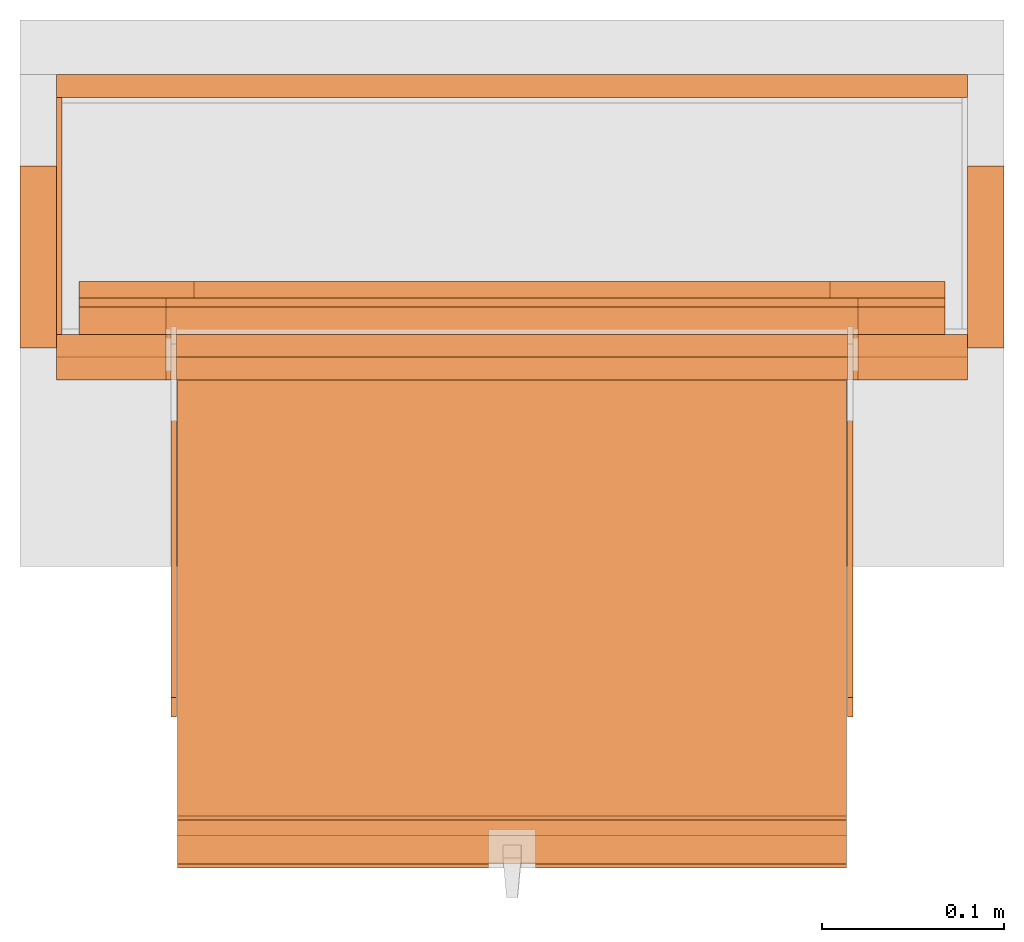
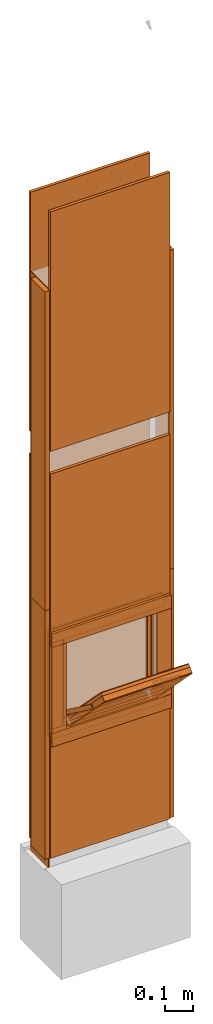
# One storey, part 1 of 3: 32 proxies, 1 opening.
"""IFC2X3 building model written with IfcOpenShell, lengths in metres."""

from ifc_helpers import new_model, entity, si_unit, converted_unit, derived_unit, money_unit, direction, frame, origin_with_axes, origin_2d_with_axis, place, context, subcontext, project, spatial, polyline, rectangle, outline, extrude, faceted_brep, source, transform, mapped, material, type_object, element, save


model = new_model("IFC2X3")

# Units and contexts
model_context = context("Model", 3, precision=1e-05, world=origin_with_axes(), true_north=direction((0.0, 1.0)))
plan_context = context("Plan", 3, precision=1e-05, world=origin_with_axes(), true_north=direction((0.0, 1.0)))
body_context = subcontext(model_context, "Body", "Model", "MODEL_VIEW")
ifc_project = project(units=[si_unit("LENGTHUNIT", "METRE"), si_unit("AREAUNIT", "SQUARE_METRE"), si_unit("VOLUMEUNIT", "CUBIC_METRE"), converted_unit("PLANEANGLEUNIT", "DEGREE", entity("IfcPlaneAngleMeasure", 0.0174532925199), si_unit("PLANEANGLEUNIT", "RADIAN"), dimensions=[0, 0, 0, 0, 0, 0, 0]), si_unit("SOLIDANGLEUNIT", "STERADIAN"), money_unit("CHF"), converted_unit("TIMEUNIT", "Year", entity("IfcTimeMeasure", 31556926.0), si_unit("TIMEUNIT", "SECOND"), dimensions=[0, 0, 1, 0, 0, 0, 0]), si_unit("MASSUNIT", "GRAM", prefix="KILO"), si_unit("THERMODYNAMICTEMPERATUREUNIT", "DEGREE_CELSIUS"), si_unit("LUMINOUSINTENSITYUNIT", "LUMEN"), si_unit("ENERGYUNIT", "JOULE", prefix="MEGA"), derived_unit("THERMALCONDUCTANCEUNIT", [(si_unit("POWERUNIT", "WATT"), 1), (si_unit("LENGTHUNIT", "METRE"), -1), (si_unit("THERMODYNAMICTEMPERATUREUNIT", "KELVIN"), -1)]), derived_unit("SPECIFICHEATCAPACITYUNIT", [(si_unit("ENERGYUNIT", "JOULE"), 1), (si_unit("MASSUNIT", "GRAM", prefix="KILO"), -1), (si_unit("THERMODYNAMICTEMPERATUREUNIT", "KELVIN"), -1)]), derived_unit("MASSDENSITYUNIT", [(si_unit("MASSUNIT", "GRAM", prefix="KILO"), 1), (si_unit("VOLUMEUNIT", "CUBIC_METRE"), -1)])], contexts=[model_context, plan_context])

# Site, building, storey
site_placement = place(None, origin_with_axes())
site = spatial("IfcSite", under=ifc_project, at=site_placement, CompositionType="ELEMENT")
building_placement = place(site_placement, origin_with_axes())
building = spatial("IfcBuilding", under=site, at=building_placement, CompositionType="ELEMENT")
storey_placement = place(building_placement, origin_with_axes())
storey = spatial("IfcBuildingStorey", under=building, at=storey_placement, Name="EG00", CompositionType="ELEMENT", Elevation=0.0)

# Proxies
ifc_material_1 = material(Name="Metall, Stahl")
building_element_proxy_type_1 = type_object("IfcBuildingElementProxyType", Name="Metall, Stahl 3", PredefinedType="NOTDEFINED")
proxy_1_placement = place(storey_placement, frame((1.55655524907, -3.75878861887, 1.15), z_axis=(0.0, 0.0, 1.0), x_axis=(0.0, -1.0, 0.0)))
element("IfcBuildingElementProxy", 1, at=proxy_1_placement, inside=storey, type_object=building_element_proxy_type_1, material=ifc_material_1, Name="Wand-005", context=body_context, shape_type="SweptSolid", body=[
    extrude(outline(polyline([(0.0, 0.0), (0.13, 0.0), (0.13, 0.003), (0.0, 0.003), (0.0, 0.0)])), origin_with_axes(), (0.0, 0.0, 1.0), 1.41),
])
proxy_2_placement = place(storey_placement, frame((1.55655524907, -3.75878861887, 0.0), z_axis=(0.0, 0.0, 1.0), x_axis=(0.0, -1.0, 0.0)))
element("IfcBuildingElementProxy", 2, at=proxy_2_placement, inside=storey, type_object=building_element_proxy_type_1, material=ifc_material_1, Name="Wand-005", context=body_context, shape_type="SweptSolid", body=[
    extrude(outline(polyline([(0.0, 0.0), (0.13, 0.0), (0.13, 0.003), (0.0, 0.003), (0.0, 0.0)])), origin_with_axes(), (0.0, 0.0, 1.0), 1.15),
])
ifc_material_2 = material(Name="Holz")
building_element_proxy_type_2 = type_object("IfcBuildingElementProxyType", Name="Holz 20", PredefinedType="NOTDEFINED")
proxy_3_placement = place(storey_placement, frame((2.07655524907, -3.79628861887, 1.15), z_axis=(0.0, 0.0, 1.0), x_axis=(0.0, -1.0, 0.0)))
element("IfcBuildingElementProxy", 3, at=proxy_3_placement, inside=storey, type_object=building_element_proxy_type_2, material=ifc_material_2, Name="Wand-003", context=body_context, shape_type="SweptSolid", body=[
    extrude(outline(polyline([(0.0, -0.02), (0.1, -0.02), (0.1, 0.0), (0.0, 0.0), (0.0, -0.02)])), origin_with_axes(), (0.0, 0.0, 1.0), 1.41),
])
proxy_4_placement = place(storey_placement, frame((1.53655524907, -3.79628861887, 1.15), z_axis=(0.0, 0.0, 1.0), x_axis=(0.0, -1.0, 0.0)))
element("IfcBuildingElementProxy", 4, at=proxy_4_placement, inside=storey, type_object=building_element_proxy_type_2, material=ifc_material_2, Name="Wand-004", context=body_context, shape_type="SweptSolid", body=[
    extrude(outline(polyline([(0.0, 0.0), (0.1, 0.0), (0.1, 0.02), (0.0, 0.02), (0.0, 0.0)])), origin_with_axes(), (0.0, 0.0, 1.0), 1.41),
])
proxy_5_placement = place(storey_placement, frame((2.07655524907, -3.79628861887, 0.05), z_axis=(0.0, 0.0, 1.0), x_axis=(0.0, -1.0, 0.0)))
element("IfcBuildingElementProxy", 5, at=proxy_5_placement, inside=storey, type_object=building_element_proxy_type_2, material=ifc_material_2, Name="Wand-003", context=body_context, shape_type="SweptSolid", body=[
    extrude(outline(polyline([(0.0, -0.02), (0.1, -0.02), (0.1, 0.0), (0.0, 0.0), (0.0, -0.02)])), origin_with_axes(), (0.0, 0.0, 1.0), 1.1),
])
proxy_6_placement = place(storey_placement, frame((1.53655524907, -3.79628861887, 0.05), z_axis=(0.0, 0.0, 1.0), x_axis=(0.0, -1.0, 0.0)))
element("IfcBuildingElementProxy", 6, at=proxy_6_placement, inside=storey, type_object=building_element_proxy_type_2, material=ifc_material_2, Name="Wand-004", context=body_context, shape_type="SweptSolid", body=[
    extrude(outline(polyline([(0.0, 0.0), (0.1, 0.0), (0.1, 0.02), (0.0, 0.02), (0.0, 0.0)])), origin_with_axes(), (0.0, 0.0, 1.0), 1.1),
])
ifc_material_3 = material(Name="Gipsplatte horizontal")
building_element_proxy_type_3 = type_object("IfcBuildingElementProxyType", Name="Gipsplatte horizontal 13", PredefinedType="NOTDEFINED")
proxy_7_placement = place(storey_placement, frame((1.55655524907, -3.74628861887, 1.85), z_axis=(0.0, 0.0, 1.0), x_axis=(1.0, 0.0, 0.0)))
element("IfcBuildingElementProxy", 7, at=proxy_7_placement, inside=storey, type_object=building_element_proxy_type_3, material=ifc_material_3, Name="Wand-004", context=body_context, shape_type="SweptSolid", body=[
    extrude(outline(polyline([(0.0, -0.0125), (0.5, -0.0125), (0.5, 0.0), (0.0, 0.0), (0.0, -0.0125)])), origin_with_axes(), (0.0, 0.0, 1.0), 1.06),
])
proxy_8_placement = place(storey_placement, frame((1.55655524907, -3.90128861887, 1.85), z_axis=(0.0, 0.0, 1.0), x_axis=(1.0, 0.0, 0.0)))
element("IfcBuildingElementProxy", 8, at=proxy_8_placement, inside=storey, type_object=building_element_proxy_type_3, material=ifc_material_3, Name="Wand-004", context=body_context, shape_type="SweptSolid", body=[
    extrude(outline(polyline([(0.0, 0.0), (0.5, 0.0), (0.5, 0.0125), (0.0, 0.0125), (0.0, 0.0)])), origin_with_axes(), (0.0, 0.0, 1.0), 1.06),
])

# Proxy, opening
proxy_9_placement = place(storey_placement, frame((1.55655524907, -3.90128861887, 0.05), z_axis=(0.0, 0.0, 1.0), x_axis=(1.0, 0.0, 0.0)))
proxy_9 = element("IfcBuildingElementProxy", 9, at=proxy_9_placement, inside=storey, type_object=building_element_proxy_type_3, material=ifc_material_3, Name="Wand-004", context=body_context, shape_type="SweptSolid", body=[
    extrude(outline(polyline([(0.0, 0.0), (0.5, 0.0), (0.5, 0.0125), (0.0, 0.0125), (0.0, 0.0)])), origin_with_axes(), (0.0, 0.0, 1.0), 1.7),
])
opening_placement = place(proxy_9_placement, frame((-1.55655524907, 3.90128861887, -0.05), z_axis=(0.0, 0.0, 1.0), x_axis=(1.0, 0.0, 0.0)))
element("IfcOpeningElement", 10, at=opening_placement, cuts=proxy_9, Name="013", context=body_context, shape_type="SweptSolid", body=[
    extrude(rectangle(XDim=0.38, YDim=0.38, at=origin_2d_with_axis()), frame((1.80655524907, -3.91378861887, 0.8), z_axis=(0.0, -1.0, 0.0), x_axis=(1.0, 0.0, 0.0)), (0.0, 0.0, -1.0), 0.0375),
])

# Proxies
proxy_10_placement = place(storey_placement, frame((1.55655524907, -3.74628861887, 0.05), z_axis=(0.0, 0.0, 1.0), x_axis=(1.0, 0.0, 0.0)))
element("IfcBuildingElementProxy", 11, at=proxy_10_placement, inside=storey, type_object=building_element_proxy_type_3, material=ifc_material_3, Name="Wand-004", context=body_context, shape_type="SweptSolid", body=[
    extrude(outline(polyline([(0.0, -0.0125), (0.5, -0.0125), (0.5, 0.0), (0.0, 0.0), (0.0, -0.0125)])), origin_with_axes(), (0.0, 0.0, 1.0), 1.7),
])
building_element_proxy_type_4 = type_object("IfcBuildingElementProxyType", Name="Holz 25", PredefinedType="NOTDEFINED")
for number, where, z_axis, x_axis, name in (
    (12, (2.05655524907, -3.88878861887, 0.99), (0.0, 0.0, 1.0), (-1.0, 0.0, 0.0), "Wand-004"),
    (13, (2.05655524907, -3.88878861887, 0.55), (0.0, 0.0, 1.0), (-1.0, 0.0, 0.0), "Wand-004"),
):
    element("IfcBuildingElementProxy", number, at=place(storey_placement, frame(where, z_axis=z_axis, x_axis=x_axis)), inside=storey, type_object=building_element_proxy_type_4, material=ifc_material_2, Name=name, context=body_context, shape_type="SweptSolid", body=[
        extrude(outline(polyline([(0.0, 0.0), (0.5, 0.0), (0.5, 0.025), (0.0, 0.025), (0.0, 0.0)])), origin_with_axes(), (0.0, 0.0, 1.0), 0.06),
    ])
for number, where, z_axis, x_axis, name in (
    (14, (1.99655524907, -3.91378861887, 0.61), (0.0, 0.0, 1.0), (1.0, 0.0, 0.0), "Wand-004"),
    (15, (1.55655524907, -3.91378861887, 0.61), (0.0, 0.0, 1.0), (1.0, 0.0, 0.0), "Wand-004"),
):
    element("IfcBuildingElementProxy", number, at=place(storey_placement, frame(where, z_axis=z_axis, x_axis=x_axis)), inside=storey, type_object=building_element_proxy_type_4, material=ifc_material_2, Name=name, context=body_context, shape_type="SweptSolid", body=[
        extrude(outline(polyline([(0.0, 0.0), (0.06, 0.0), (0.06, 0.025), (0.0, 0.025), (0.0, 0.0)])), origin_with_axes(), (0.0, 0.0, 1.0), 0.38),
    ])
building_element_proxy_type_5 = type_object("IfcBuildingElementProxyType", Name="Holz 15", PredefinedType="NOTDEFINED")
for number, where, z_axis, x_axis, name in (
    (16, (2.04405524907, -3.87378861887, 0.99), (0.0, 0.0, 1.0), (-1.0, 0.0, 0.0), "Wand-004"),
    (17, (2.04405524907, -3.87378861887, 0.5625), (0.0, 0.0, 1.0), (-1.0, 0.0, 0.0), "Wand-004"),
):
    element("IfcBuildingElementProxy", number, at=place(storey_placement, frame(where, z_axis=z_axis, x_axis=x_axis)), inside=storey, type_object=building_element_proxy_type_5, material=ifc_material_2, Name=name, context=body_context, shape_type="SweptSolid", body=[
        extrude(outline(polyline([(0.0, 0.0), (0.475, 0.0), (0.475, 0.015), (0.0, 0.015), (0.0, 0.0)])), origin_with_axes(), (0.0, 0.0, 1.0), 0.0475),
    ])
for number, where, z_axis, x_axis, name in (
    (18, (1.99655524907, -3.88878861887, 0.61), (0.0, 0.0, 1.0), (1.0, 0.0, 0.0), "Wand-004"),
    (19, (1.56905524907, -3.88878861887, 0.61), (0.0, 0.0, 1.0), (1.0, 0.0, 0.0), "Wand-004"),
):
    element("IfcBuildingElementProxy", number, at=place(storey_placement, frame(where, z_axis=z_axis, x_axis=x_axis)), inside=storey, type_object=building_element_proxy_type_5, material=ifc_material_2, Name=name, context=body_context, shape_type="SweptSolid", body=[
        extrude(outline(polyline([(0.0, 0.0), (0.0475, 0.0), (0.0475, 0.015), (0.0, 0.015), (0.0, 0.0)])), origin_with_axes(), (0.0, 0.0, 1.0), 0.38),
    ])
building_element_proxy_type_6 = type_object("IfcBuildingElementProxyType", Name="Holz 5", PredefinedType="NOTDEFINED")
for number, where, z_axis, x_axis, name in (
    (20, (2.04405524907, -3.87378861887, 1.0), (0.0, 0.0, 1.0), (-1.0, 0.0, 0.0), "Wand-004"),
    (21, (2.04405524907, -3.87378861887, 0.5625), (0.0, 0.0, 1.0), (-1.0, 0.0, 0.0), "Wand-004"),
):
    element("IfcBuildingElementProxy", number, at=place(storey_placement, frame(where, z_axis=z_axis, x_axis=x_axis)), inside=storey, type_object=building_element_proxy_type_6, material=ifc_material_2, Name=name, context=body_context, shape_type="SweptSolid", body=[
        extrude(outline(polyline([(0.0, -0.005), (0.475, -0.005), (0.475, 0.0), (0.0, 0.0), (0.0, -0.005)])), origin_with_axes(), (0.0, 0.0, 1.0), 0.0375),
    ])
for number, where, z_axis, x_axis, name in (
    (22, (1.99655524907, -3.87378861887, 0.6), (0.0, 0.0, 1.0), (1.0, 0.0, 0.0), "Wand-004"),
    (23, (1.56905524907, -3.87378861887, 0.6), (0.0, 0.0, 1.0), (1.0, 0.0, 0.0), "Wand-004"),
):
    element("IfcBuildingElementProxy", number, at=place(storey_placement, frame(where, z_axis=z_axis, x_axis=x_axis)), inside=storey, type_object=building_element_proxy_type_6, material=ifc_material_2, Name=name, context=body_context, shape_type="SweptSolid", body=[
        extrude(outline(polyline([(0.0, 0.0), (0.0475, 0.0), (0.0475, 0.005), (0.0, 0.005), (0.0, 0.0)])), origin_with_axes(), (0.0, 0.0, 1.0), 0.4),
    ])
building_element_proxy_type_7 = type_object("IfcBuildingElementProxyType", Name="Holz 9", PredefinedType="NOTDEFINED")
for number, where, z_axis, x_axis, name in (
    (24, (2.04405524907, -3.86878861887, 0.975), (0.0, 0.0, 1.0), (-1.0, 0.0, 0.0), "Wand-004"),
    (25, (2.04405524907, -3.86878861887, 0.5625), (0.0, 0.0, 1.0), (-1.0, 0.0, 0.0), "Wand-004"),
):
    element("IfcBuildingElementProxy", number, at=place(storey_placement, frame(where, z_axis=z_axis, x_axis=x_axis)), inside=storey, type_object=building_element_proxy_type_7, material=ifc_material_2, Name=name, context=body_context, shape_type="SweptSolid", body=[
        extrude(outline(polyline([(0.0, -0.009), (0.475, -0.009), (0.475, 0.0), (0.0, 0.0), (0.0, -0.009)])), origin_with_axes(), (0.0, 0.0, 1.0), 0.0625),
    ])
for number, where, z_axis, x_axis, name in (
    (26, (1.98105524907, -3.86878861887, 0.625), (0.0, 0.0, 1.0), (1.0, 0.0, 0.0), "Wand-004"),
    (27, (1.56905524907, -3.86878861887, 0.625), (0.0, 0.0, 1.0), (1.0, 0.0, 0.0), "Wand-004"),
):
    element("IfcBuildingElementProxy", number, at=place(storey_placement, frame(where, z_axis=z_axis, x_axis=x_axis)), inside=storey, type_object=building_element_proxy_type_7, material=ifc_material_2, Name=name, context=body_context, shape_type="SweptSolid", body=[
        extrude(outline(polyline([(0.0, 0.0), (0.063, 0.0), (0.063, 0.009), (0.0, 0.009), (0.0, 0.0)])), origin_with_axes(), (0.0, 0.0, 1.0), 0.35),
    ])
ifc_material_4 = material(Name="Metall, Aluminium")
building_element_proxy_type_8 = type_object("IfcBuildingElementProxyType", Name="Metall, Aluminium", PredefinedType="NOTDEFINED")
shared_shape_1 = source(origin_with_axes(), body_context, "Body", "Brep", [
    faceted_brep([(16.1060766769, -3.29167330347, 0.736478855326), (16.1060766769, -3.65867330347, 0.736478855326), (16.1060766769, -3.65867330347, 1.10947885533), (16.1060766769, -3.29167330347, 1.10947885533), (16.1091136769, -3.29167330347, 0.736478855326), (16.1091136769, -3.65867330347, 0.736478855326), (16.1091136769, -3.65867330347, 1.10947885533), (16.1091136769, -3.29167330347, 1.10947885533)], [[[0, 1, 2, 3]], [[1, 0, 4, 5]], [[2, 1, 5, 6]], [[3, 2, 6, 7]], [[0, 3, 7, 4]], [[5, 4, 7, 6]]]),
])
proxy_11_placement = place(storey_placement, frame((5.28172855254, 8.09555096902, 11.375802015), z_axis=(0.0, -0.700249431637, 0.713898265506), x_axis=(0.0, -0.713898265506, -0.700249431637)))
element("IfcBuildingElementProxy", 28, at=proxy_11_placement, inside=storey, type_object=building_element_proxy_type_8, material=ifc_material_4, Name="Wand-004", context=body_context, shape_type="MappedRepresentation", body=[
    mapped(shared_shape_1, transform((0.0, 0.0, 0.0))),
])
building_element_proxy_type_9 = type_object("IfcBuildingElementProxyType", Name="Holz", PredefinedType="NOTDEFINED")
shared_shape_2 = source(origin_with_axes(), body_context, "Body", "Brep", [
    faceted_brep([(16.0840766769, -3.65867330347, 1.10947885533), (16.0840766769, -3.29167330347, 1.10947885533), (16.0840766769, -3.29167330347, 0.736478855326), (16.0840766769, -3.65867330347, 0.736478855326), (16.1060766769, -3.65867330347, 1.10947885533), (16.1060766769, -3.29167330347, 1.10947885533), (16.1060766769, -3.29167330347, 0.736478855326), (16.1060766769, -3.65867330347, 0.736478855326)], [[[0, 1, 2, 3]], [[1, 0, 4, 5]], [[2, 1, 5, 6]], [[3, 2, 6, 7]], [[0, 3, 7, 4]], [[4, 7, 6, 5]]]),
])
proxy_12_placement = place(storey_placement, frame((5.28172855254, 8.09555096902, 11.375802015), z_axis=(0.0, -0.700249431637, 0.713898265506), x_axis=(0.0, -0.713898265506, -0.700249431637)))
element("IfcBuildingElementProxy", 29, at=proxy_12_placement, inside=storey, type_object=building_element_proxy_type_9, material=ifc_material_2, Name="Wand-004", context=body_context, shape_type="MappedRepresentation", body=[
    mapped(shared_shape_2, transform((0.0, 0.0, 0.0))),
])
building_element_proxy_type_10 = type_object("IfcBuildingElementProxyType", Name="Gipsplatte horizontal", PredefinedType="NOTDEFINED")
shared_shape_3 = source(origin_with_axes(), body_context, "Body", "Brep", [
    faceted_brep([(16.0720766769, -3.65867330347, 1.10947885533), (16.0720766769, -3.29167330347, 1.10947885533), (16.0720766769, -3.29167330347, 0.736478855326), (16.0720766769, -3.65867330347, 0.736478855326), (16.0840766769, -3.65867330347, 1.10947885533), (16.0840766769, -3.29167330347, 1.10947885533), (16.0840766769, -3.29167330347, 0.736478855326), (16.0840766769, -3.65867330347, 0.736478855326)], [[[0, 1, 2, 3]], [[1, 0, 4, 5]], [[2, 1, 5, 6]], [[3, 2, 6, 7]], [[0, 3, 7, 4]], [[4, 7, 6, 5]]]),
])
proxy_13_placement = place(storey_placement, frame((5.28172855254, 8.09555096902, 11.375802015), z_axis=(0.0, -0.700249431637, 0.713898265506), x_axis=(0.0, -0.713898265506, -0.700249431637)))
element("IfcBuildingElementProxy", 30, at=proxy_13_placement, inside=storey, type_object=building_element_proxy_type_10, material=ifc_material_3, Name="Wand-004", context=body_context, shape_type="MappedRepresentation", body=[
    mapped(shared_shape_3, transform((0.0, 0.0, 0.0))),
])
shared_shape_4 = source(origin_with_axes(), body_context, "Body", "Brep", [
    faceted_brep([(16.0690396769, -3.29167330347, 0.736478855326), (16.0690396769, -3.65867330347, 0.736478855326), (16.0690396769, -3.65867330347, 1.10947885533), (16.0690396769, -3.29167330347, 1.10947885533), (16.0720766769, -3.29167330347, 0.736478855326), (16.0720766769, -3.65867330347, 0.736478855326), (16.0720766769, -3.65867330347, 1.10947885533), (16.0720766769, -3.29167330347, 1.10947885533)], [[[0, 1, 2, 3]], [[1, 0, 4, 5]], [[2, 1, 5, 6]], [[3, 2, 6, 7]], [[0, 3, 7, 4]], [[5, 4, 7, 6]]]),
])
proxy_14_placement = place(storey_placement, frame((5.28172855254, 8.09555096902, 11.375802015), z_axis=(0.0, -0.700249431637, 0.713898265506), x_axis=(0.0, -0.713898265506, -0.700249431637)))
element("IfcBuildingElementProxy", 31, at=proxy_14_placement, inside=storey, type_object=building_element_proxy_type_8, material=ifc_material_4, Name="Wand-004", context=body_context, shape_type="MappedRepresentation", body=[
    mapped(shared_shape_4, transform((0.0, 0.0, 0.0))),
])
shared_shape_5 = source(origin_with_axes(), body_context, "Body", "Brep", [
    faceted_brep([(16.1152851057, -3.58730556817, 0.89), (16.1152851057, -3.59030556817, 0.89), (16.1152851057, -3.59030556817, 1.14), (16.1152851057, -3.58730556817, 1.14), (16.1332851057, -3.59030556817, 0.89), (16.1332851057, -3.58730556817, 0.89), (16.1332851057, -3.59030556817, 1.14), (16.1332851057, -3.58730556817, 1.14)], [[[0, 1, 2, 3]], [[4, 1, 0, 5]], [[1, 4, 6, 2]], [[2, 6, 7, 3]], [[0, 3, 7, 5]], [[4, 5, 7, 6]]]),
])
for number, where, z_axis, x_axis, name in (
    (32, (5.20986081724, 6.43632697465, 13.081222354), (0.0, -0.80277012101, 0.596288632135), (0.0, -0.596288632135, -0.80277012101), "Wand-004"),
    (33, (5.58086081724, 6.43632697465, 13.081222354), (0.0, -0.80277012101, 0.596288632135), (0.0, -0.596288632135, -0.80277012101), "Wand-004"),
):
    element("IfcBuildingElementProxy", number, at=place(storey_placement, frame(where, z_axis=z_axis, x_axis=x_axis)), inside=storey, type_object=building_element_proxy_type_8, material=ifc_material_4, Name=name, context=body_context, shape_type="MappedRepresentation", body=[
        mapped(shared_shape_5, transform((0.0, 0.0, 0.0))),
    ])

save(model, "model.ifc")
